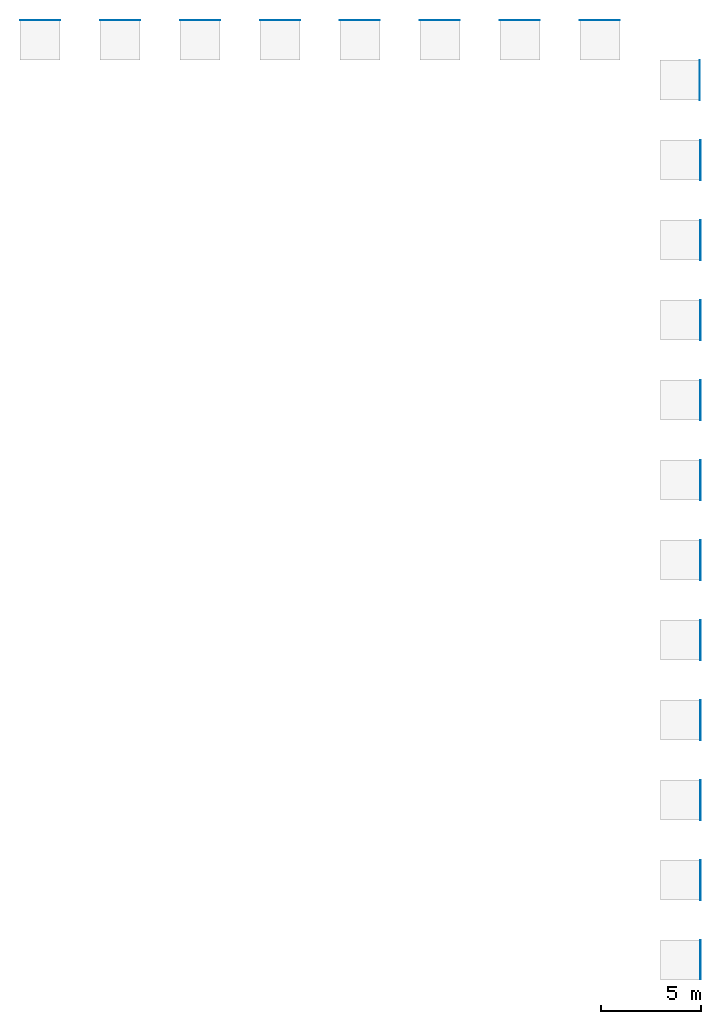
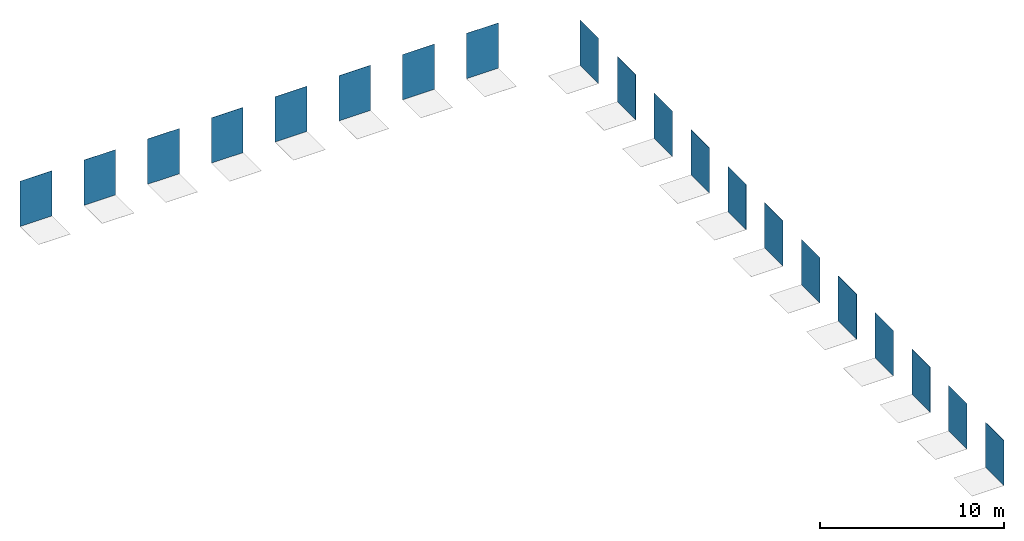
# One storey, part 1 of 2: 20 walls.
"""IFC2X3 building model written with IfcOpenShell, lengths in millimetres."""

from ifc_helpers import new_model, entity, si_unit, converted_unit, derived_unit, direction, frame, frame_2d, origin, place, context, subcontext, project, spatial, rectangle, extrude, material, layer, layer_set, layer_usage, type_object, element, save


model = new_model("IFC2X3")

# Units and contexts
model_context = context("Model", 3, precision=0.01, world=origin(), true_north=direction((6.12303176911189e-17, 1.0)))
body_context = subcontext(model_context, "Body", "Model", "MODEL_VIEW")
ifc_project = project(units=[si_unit("LENGTHUNIT", "METRE", prefix="MILLI"), si_unit("AREAUNIT", "SQUARE_METRE"), si_unit("VOLUMEUNIT", "CUBIC_METRE"), converted_unit("PLANEANGLEUNIT", "DEGREE", entity("IfcRatioMeasure", 0.0174532925199433), si_unit("PLANEANGLEUNIT", "RADIAN"), dimensions=[0, 0, 0, 0, 0, 0, 0]), si_unit("MASSUNIT", "GRAM", prefix="KILO"), derived_unit("MASSDENSITYUNIT", [(si_unit("MASSUNIT", "GRAM", prefix="KILO"), 1), (si_unit("LENGTHUNIT", "METRE"), -3)]), si_unit("TIMEUNIT", "SECOND"), si_unit("FREQUENCYUNIT", "HERTZ"), si_unit("THERMODYNAMICTEMPERATUREUNIT", "DEGREE_CELSIUS"), derived_unit("THERMALTRANSMITTANCEUNIT", [(si_unit("MASSUNIT", "GRAM", prefix="KILO"), 1), (si_unit("THERMODYNAMICTEMPERATUREUNIT", "KELVIN"), -1), (si_unit("TIMEUNIT", "SECOND"), -3)]), derived_unit("VOLUMETRICFLOWRATEUNIT", [(si_unit("LENGTHUNIT", "METRE"), 3), (si_unit("TIMEUNIT", "SECOND"), -1)]), si_unit("ELECTRICCURRENTUNIT", "AMPERE"), si_unit("ELECTRICVOLTAGEUNIT", "VOLT"), si_unit("POWERUNIT", "WATT"), si_unit("FORCEUNIT", "NEWTON", prefix="KILO"), si_unit("ILLUMINANCEUNIT", "LUX"), si_unit("LUMINOUSFLUXUNIT", "LUMEN"), si_unit("LUMINOUSINTENSITYUNIT", "CANDELA"), derived_unit("USERDEFINED", [(si_unit("MASSUNIT", "GRAM", prefix="KILO"), -1), (si_unit("LENGTHUNIT", "METRE"), -2), (si_unit("TIMEUNIT", "SECOND"), 3), (si_unit("LUMINOUSFLUXUNIT", "LUMEN"), 1)]), derived_unit("LINEARVELOCITYUNIT", [(si_unit("LENGTHUNIT", "METRE"), 1), (si_unit("TIMEUNIT", "SECOND"), -1)]), si_unit("PRESSUREUNIT", "PASCAL"), derived_unit("USERDEFINED", [(si_unit("LENGTHUNIT", "METRE"), -2), (si_unit("MASSUNIT", "GRAM", prefix="KILO"), 1), (si_unit("TIMEUNIT", "SECOND"), -2)])], contexts=[model_context])

# Site, building, storey
site_placement = place(None, origin())
site = spatial("IfcSite", under=ifc_project, at=site_placement, CompositionType="ELEMENT")
building_placement = place(site_placement, origin())
building = spatial("IfcBuilding", under=site, at=building_placement, CompositionType="ELEMENT")
storey_placement = place(building_placement, origin())
storey = spatial("IfcBuildingStorey", under=building, at=storey_placement, Name="Level 1", CompositionType="ELEMENT", Elevation=0.0)

# Walls
ifc_material_1 = material(Name="PGR_CeramicTiles_Acero-193x1200mm")
ifc_layer_1 = layer(ifc_material_1, 11.5)
ifc_layer_set_1 = layer_set([ifc_layer_1], Name="Basic Wall:PGR_CeramicTiles_Acero-193x1200mm")
ifc_layer_usage_1 = layer_usage(ifc_layer_set_1, "AXIS2", "POSITIVE", -5.75)
wall_type_1 = type_object("IfcWallType", Name="Basic Wall:PGR_CeramicTiles_Acero-193x1200mm", PredefinedType="STANDARD", material=ifc_layer_set_1)
wall_1_placement = place(storey_placement, frame((3521.32742659015, 25498.0173252312, 0.0), z_axis=(0.0, 0.0, 1.0), x_axis=(0.0, -1.0, 0.0)))
element("IfcWallStandardCase", 1, at=wall_1_placement, inside=storey, type_object=wall_type_1, material=ifc_layer_usage_1, Name="Basic Wall:PGR_CeramicTiles_Acero-193x1200mm", ObjectType="Basic Wall:PGR_CeramicTiles_Acero-193x1200mm", context=body_context, shape_type="SweptSolid", body=[
    extrude(rectangle(XDim=2000.0, YDim=11.4999999999996, at=frame_2d((1000.0, 7.54951656745106e-15), x_axis=(-1.0, 0.0))), origin(), (0.0, 0.0, 1.0), 3000.00000000014),
])
ifc_material_2 = material(Name="PGR_CeramicTiles_Acero-193x1800mm")
ifc_layer_2 = layer(ifc_material_2, 11.5)
ifc_layer_set_2 = layer_set([ifc_layer_2], Name="Basic Wall:PGR_CeramicTiles_Acero-193x1800mm")
ifc_layer_usage_2 = layer_usage(ifc_layer_set_2, "AXIS2", "POSITIVE", -5.75)
wall_type_2 = type_object("IfcWallType", Name="Basic Wall:PGR_CeramicTiles_Acero-193x1800mm", PredefinedType="STANDARD", material=ifc_layer_set_2)
wall_2_placement = place(storey_placement, frame((3521.32742659015, 29498.0173252312, 0.0), z_axis=(0.0, 0.0, 1.0), x_axis=(0.0, -1.0, 0.0)))
element("IfcWallStandardCase", 2, at=wall_2_placement, inside=storey, type_object=wall_type_2, material=ifc_layer_usage_2, Name="Basic Wall:PGR_CeramicTiles_Acero-193x1800mm", ObjectType="Basic Wall:PGR_CeramicTiles_Acero-193x1800mm", context=body_context, shape_type="SweptSolid", body=[
    extrude(rectangle(XDim=2000.0, YDim=11.4999999999996, at=frame_2d((1000.0, 7.54951656745106e-15), x_axis=(-1.0, 0.0))), origin(), (0.0, 0.0, 1.0), 3000.00000000014),
])
ifc_material_3 = material(Name="PGR_CeramicTiles_Acero-294x1200mm")
ifc_layer_3 = layer(ifc_material_3, 11.5)
ifc_layer_set_3 = layer_set([ifc_layer_3], Name="Basic Wall:PGR_CeramicTiles_Acero-294x1200mm")
ifc_layer_usage_3 = layer_usage(ifc_layer_set_3, "AXIS2", "POSITIVE", -5.75)
wall_type_3 = type_object("IfcWallType", Name="Basic Wall:PGR_CeramicTiles_Acero-294x1200mm", PredefinedType="STANDARD", material=ifc_layer_set_3)
wall_3_placement = place(storey_placement, frame((-2498.42257340996, 71492.2673252312, 0.0)))
element("IfcWallStandardCase", 3, at=wall_3_placement, inside=storey, type_object=wall_type_3, material=ifc_layer_usage_3, Name="Basic Wall:PGR_CeramicTiles_Acero-294x1200mm", ObjectType="Basic Wall:PGR_CeramicTiles_Acero-294x1200mm", context=body_context, shape_type="SweptSolid", body=[
    extrude(rectangle(XDim=2000.0, YDim=11.500000000006, at=frame_2d((1000.0, 1.8052226380405e-12), x_axis=(-1.0, 0.0))), origin(), (0.0, 0.0, 1.0), 3000.00000000014),
])
ifc_material_4 = material(Name="PGR_CeramicTiles_Acero-294x1800mm")
ifc_layer_4 = layer(ifc_material_4, 11.5)
ifc_layer_set_4 = layer_set([ifc_layer_4], Name="Basic Wall:PGR_CeramicTiles_Acero-294x1800mm")
ifc_layer_usage_4 = layer_usage(ifc_layer_set_4, "AXIS2", "POSITIVE", -5.75)
wall_type_4 = type_object("IfcWallType", Name="Basic Wall:PGR_CeramicTiles_Acero-294x1800mm", PredefinedType="STANDARD", material=ifc_layer_set_4)
wall_4_placement = place(storey_placement, frame((-6498.42257340995, 71492.2673252312, 0.0)))
element("IfcWallStandardCase", 4, at=wall_4_placement, inside=storey, type_object=wall_type_4, material=ifc_layer_usage_4, Name="Basic Wall:PGR_CeramicTiles_Acero-294x1800mm", ObjectType="Basic Wall:PGR_CeramicTiles_Acero-294x1800mm", context=body_context, shape_type="SweptSolid", body=[
    extrude(rectangle(XDim=2000.0, YDim=11.500000000006, at=frame_2d((1000.0, 1.8052226380405e-12), x_axis=(-1.0, 0.0))), origin(), (0.0, 0.0, 1.0), 3000.00000000014),
])
ifc_material_5 = material(Name="PGR_CeramicTiles_Acero_Ant.-193x1800mm")
ifc_layer_5 = layer(ifc_material_5, 11.5)
ifc_layer_set_5 = layer_set([ifc_layer_5], Name="Basic Wall:PGR_CeramicTiles_Acero_Ant.-193x1800mm")
ifc_layer_usage_5 = layer_usage(ifc_layer_set_5, "AXIS2", "POSITIVE", -5.75)
wall_type_5 = type_object("IfcWallType", Name="Basic Wall:PGR_CeramicTiles_Acero_Ant.-193x1800mm", PredefinedType="STANDARD", material=ifc_layer_set_5)
wall_5_placement = place(storey_placement, frame((3521.32742659013, 33498.0173252312, 0.0), z_axis=(0.0, 0.0, 1.0), x_axis=(0.0, -1.0, 0.0)))
element("IfcWallStandardCase", 5, at=wall_5_placement, inside=storey, type_object=wall_type_5, material=ifc_layer_usage_5, Name="Basic Wall:PGR_CeramicTiles_Acero_Ant.-193x1800mm", ObjectType="Basic Wall:PGR_CeramicTiles_Acero_Ant.-193x1800mm", context=body_context, shape_type="SweptSolid", body=[
    extrude(rectangle(XDim=2000.0, YDim=11.4999999999996, at=frame_2d((1000.0, 7.54951656745106e-15), x_axis=(-1.0, 0.0))), origin(), (0.0, 0.0, 1.0), 3000.00000000014),
])
ifc_material_6 = material(Name="PGR_CeramicTiles_Arce-193x1200mm")
ifc_layer_6 = layer(ifc_material_6, 11.5)
ifc_layer_set_6 = layer_set([ifc_layer_6], Name="Basic Wall:PGR_CeramicTiles_Arce-193x1200mm")
ifc_layer_usage_6 = layer_usage(ifc_layer_set_6, "AXIS2", "POSITIVE", -5.75)
wall_type_6 = type_object("IfcWallType", Name="Basic Wall:PGR_CeramicTiles_Arce-193x1200mm", PredefinedType="STANDARD", material=ifc_layer_set_6)
wall_6_placement = place(storey_placement, frame((3521.32742659013, 37498.0173252312, 0.0), z_axis=(0.0, 0.0, 1.0), x_axis=(0.0, -1.0, 0.0)))
element("IfcWallStandardCase", 6, at=wall_6_placement, inside=storey, type_object=wall_type_6, material=ifc_layer_usage_6, Name="Basic Wall:PGR_CeramicTiles_Arce-193x1200mm", ObjectType="Basic Wall:PGR_CeramicTiles_Arce-193x1200mm", context=body_context, shape_type="SweptSolid", body=[
    extrude(rectangle(XDim=2000.0, YDim=11.4999999999996, at=frame_2d((1000.0, 7.54951656745106e-15), x_axis=(-1.0, 0.0))), origin(), (0.0, 0.0, 1.0), 3000.00000000014),
])
ifc_material_7 = material(Name="PGR_CeramicTiles_Arce-193x1800mm")
ifc_layer_7 = layer(ifc_material_7, 11.5)
ifc_layer_set_7 = layer_set([ifc_layer_7], Name="Basic Wall:PGR_CeramicTiles_Arce-193x1800mm")
ifc_layer_usage_7 = layer_usage(ifc_layer_set_7, "AXIS2", "POSITIVE", -5.75)
wall_type_7 = type_object("IfcWallType", Name="Basic Wall:PGR_CeramicTiles_Arce-193x1800mm", PredefinedType="STANDARD", material=ifc_layer_set_7)
wall_7_placement = place(storey_placement, frame((3521.32742659013, 41498.0173252312, 0.0), z_axis=(0.0, 0.0, 1.0), x_axis=(0.0, -1.0, 0.0)))
element("IfcWallStandardCase", 7, at=wall_7_placement, inside=storey, type_object=wall_type_7, material=ifc_layer_usage_7, Name="Basic Wall:PGR_CeramicTiles_Arce-193x1800mm", ObjectType="Basic Wall:PGR_CeramicTiles_Arce-193x1800mm", context=body_context, shape_type="SweptSolid", body=[
    extrude(rectangle(XDim=2000.0, YDim=11.4999999999996, at=frame_2d((1000.0, 7.54951656745106e-15), x_axis=(-1.0, 0.0))), origin(), (0.0, 0.0, 1.0), 3000.00000000014),
])
ifc_material_8 = material(Name="PGR_CeramicTiles_Arce-294x1200mm")
ifc_layer_8 = layer(ifc_material_8, 11.5)
ifc_layer_set_8 = layer_set([ifc_layer_8], Name="Basic Wall:PGR_CeramicTiles_Arce-294x1200mm")
ifc_layer_usage_8 = layer_usage(ifc_layer_set_8, "AXIS2", "POSITIVE", -5.75)
wall_type_8 = type_object("IfcWallType", Name="Basic Wall:PGR_CeramicTiles_Arce-294x1200mm", PredefinedType="STANDARD", material=ifc_layer_set_8)
wall_8_placement = place(storey_placement, frame((-10498.42257341, 71492.2673252312, 0.0)))
element("IfcWallStandardCase", 8, at=wall_8_placement, inside=storey, type_object=wall_type_8, material=ifc_layer_usage_8, Name="Basic Wall:PGR_CeramicTiles_Arce-294x1200mm", ObjectType="Basic Wall:PGR_CeramicTiles_Arce-294x1200mm", context=body_context, shape_type="SweptSolid", body=[
    extrude(rectangle(XDim=2000.0, YDim=11.500000000006, at=frame_2d((1000.0, 1.8052226380405e-12), x_axis=(-1.0, 0.0))), origin(), (0.0, 0.0, 1.0), 3000.00000000014),
])
ifc_material_9 = material(Name="PGR_CeramicTiles_Arce-294x1800mm")
ifc_layer_9 = layer(ifc_material_9, 11.5)
ifc_layer_set_9 = layer_set([ifc_layer_9], Name="Basic Wall:PGR_CeramicTiles_Arce-294x1800mm")
ifc_layer_usage_9 = layer_usage(ifc_layer_set_9, "AXIS2", "POSITIVE", -5.75)
wall_type_9 = type_object("IfcWallType", Name="Basic Wall:PGR_CeramicTiles_Arce-294x1800mm", PredefinedType="STANDARD", material=ifc_layer_set_9)
wall_9_placement = place(storey_placement, frame((-14498.42257341, 71492.2673252312, 0.0)))
element("IfcWallStandardCase", 9, at=wall_9_placement, inside=storey, type_object=wall_type_9, material=ifc_layer_usage_9, Name="Basic Wall:PGR_CeramicTiles_Arce-294x1800mm", ObjectType="Basic Wall:PGR_CeramicTiles_Arce-294x1800mm", context=body_context, shape_type="SweptSolid", body=[
    extrude(rectangle(XDim=2000.0, YDim=11.500000000006, at=frame_2d((1000.0, 1.8052226380405e-12), x_axis=(-1.0, 0.0))), origin(), (0.0, 0.0, 1.0), 3000.00000000014),
])
ifc_material_10 = material(Name="PGR_CeramicTiles_Arce_Ant.-193x1800mm")
ifc_layer_10 = layer(ifc_material_10, 11.5)
ifc_layer_set_10 = layer_set([ifc_layer_10], Name="Basic Wall:PGR_CeramicTiles_Arce_Ant.-193x1800mm")
ifc_layer_usage_10 = layer_usage(ifc_layer_set_10, "AXIS2", "POSITIVE", -5.75)
wall_type_10 = type_object("IfcWallType", Name="Basic Wall:PGR_CeramicTiles_Arce_Ant.-193x1800mm", PredefinedType="STANDARD", material=ifc_layer_set_10)
wall_10_placement = place(storey_placement, frame((3521.32742659012, 45498.0173252312, 0.0), z_axis=(0.0, 0.0, 1.0), x_axis=(0.0, -1.0, 0.0)))
element("IfcWallStandardCase", 10, at=wall_10_placement, inside=storey, type_object=wall_type_10, material=ifc_layer_usage_10, Name="Basic Wall:PGR_CeramicTiles_Arce_Ant.-193x1800mm", ObjectType="Basic Wall:PGR_CeramicTiles_Arce_Ant.-193x1800mm", context=body_context, shape_type="SweptSolid", body=[
    extrude(rectangle(XDim=2000.0, YDim=11.4999999999996, at=frame_2d((1000.0, 7.54951656745106e-15), x_axis=(-1.0, 0.0))), origin(), (0.0, 0.0, 1.0), 3000.00000000014),
])
ifc_material_11 = material(Name="PGR_CeramicTiles_Natural-193x1200mm")
ifc_layer_11 = layer(ifc_material_11, 11.5)
ifc_layer_set_11 = layer_set([ifc_layer_11], Name="Basic Wall:PGR_CeramicTiles_Natural-193x1200mm")
ifc_layer_usage_11 = layer_usage(ifc_layer_set_11, "AXIS2", "POSITIVE", -5.75)
wall_type_11 = type_object("IfcWallType", Name="Basic Wall:PGR_CeramicTiles_Natural-193x1200mm", PredefinedType="STANDARD", material=ifc_layer_set_11)
wall_11_placement = place(storey_placement, frame((3521.32742659014, 49498.0173252312, 0.0), z_axis=(0.0, 0.0, 1.0), x_axis=(0.0, -1.0, 0.0)))
element("IfcWallStandardCase", 11, at=wall_11_placement, inside=storey, type_object=wall_type_11, material=ifc_layer_usage_11, Name="Basic Wall:PGR_CeramicTiles_Natural-193x1200mm", ObjectType="Basic Wall:PGR_CeramicTiles_Natural-193x1200mm", context=body_context, shape_type="SweptSolid", body=[
    extrude(rectangle(XDim=2000.0, YDim=11.4999999999996, at=frame_2d((1000.0, 8.39328606616618e-14), x_axis=(-1.0, 0.0))), origin(), (0.0, 0.0, 1.0), 3000.00000000014),
])
ifc_material_12 = material(Name="PGR_CeramicTiles_Natural-193x1800mm")
ifc_layer_12 = layer(ifc_material_12, 11.5)
ifc_layer_set_12 = layer_set([ifc_layer_12], Name="Basic Wall:PGR_CeramicTiles_Natural-193x1800mm")
ifc_layer_usage_12 = layer_usage(ifc_layer_set_12, "AXIS2", "POSITIVE", -5.75)
wall_type_12 = type_object("IfcWallType", Name="Basic Wall:PGR_CeramicTiles_Natural-193x1800mm", PredefinedType="STANDARD", material=ifc_layer_set_12)
wall_12_placement = place(storey_placement, frame((3521.32742659014, 53498.0173252312, 0.0), z_axis=(0.0, 0.0, 1.0), x_axis=(0.0, -1.0, 0.0)))
element("IfcWallStandardCase", 12, at=wall_12_placement, inside=storey, type_object=wall_type_12, material=ifc_layer_usage_12, Name="Basic Wall:PGR_CeramicTiles_Natural-193x1800mm", ObjectType="Basic Wall:PGR_CeramicTiles_Natural-193x1800mm", context=body_context, shape_type="SweptSolid", body=[
    extrude(rectangle(XDim=2000.0, YDim=11.4999999999996, at=frame_2d((1000.0, 8.39328606616618e-14), x_axis=(-1.0, 0.0))), origin(), (0.0, 0.0, 1.0), 3000.00000000014),
])
ifc_material_13 = material(Name="PGR_CeramicTiles_Natural-294x1200mm")
ifc_layer_13 = layer(ifc_material_13, 11.5)
ifc_layer_set_13 = layer_set([ifc_layer_13], Name="Basic Wall:PGR_CeramicTiles_Natural-294x1200mm")
ifc_layer_usage_13 = layer_usage(ifc_layer_set_13, "AXIS2", "POSITIVE", -5.75)
wall_type_13 = type_object("IfcWallType", Name="Basic Wall:PGR_CeramicTiles_Natural-294x1200mm", PredefinedType="STANDARD", material=ifc_layer_set_13)
wall_13_placement = place(storey_placement, frame((-18498.4225734099, 71492.2673252312, 0.0)))
element("IfcWallStandardCase", 13, at=wall_13_placement, inside=storey, type_object=wall_type_13, material=ifc_layer_usage_13, Name="Basic Wall:PGR_CeramicTiles_Natural-294x1200mm", ObjectType="Basic Wall:PGR_CeramicTiles_Natural-294x1200mm", context=body_context, shape_type="SweptSolid", body=[
    extrude(rectangle(XDim=2000.0, YDim=11.5000000000061, at=frame_2d((1000.0, -1.36024524977074e-12), x_axis=(-1.0, 0.0))), origin(), (0.0, 0.0, 1.0), 3000.00000000014),
])
ifc_material_14 = material(Name="PGR_CeramicTiles_Natural-294x1800mm")
ifc_layer_14 = layer(ifc_material_14, 11.5)
ifc_layer_set_14 = layer_set([ifc_layer_14], Name="Basic Wall:PGR_CeramicTiles_Natural-294x1800mm")
ifc_layer_usage_14 = layer_usage(ifc_layer_set_14, "AXIS2", "POSITIVE", -5.75)
wall_type_14 = type_object("IfcWallType", Name="Basic Wall:PGR_CeramicTiles_Natural-294x1800mm", PredefinedType="STANDARD", material=ifc_layer_set_14)
wall_14_placement = place(storey_placement, frame((-22498.4225734099, 71492.2673252312, 0.0)))
element("IfcWallStandardCase", 14, at=wall_14_placement, inside=storey, type_object=wall_type_14, material=ifc_layer_usage_14, Name="Basic Wall:PGR_CeramicTiles_Natural-294x1800mm", ObjectType="Basic Wall:PGR_CeramicTiles_Natural-294x1800mm", context=body_context, shape_type="SweptSolid", body=[
    extrude(rectangle(XDim=2000.0, YDim=11.5000000000061, at=frame_2d((1000.0, -1.36024524977074e-12), x_axis=(-1.0, 0.0))), origin(), (0.0, 0.0, 1.0), 3000.00000000014),
])
ifc_material_15 = material(Name="PGR_CeramicTiles_Natural_Ant.-193x1800mm")
ifc_layer_15 = layer(ifc_material_15, 11.5)
ifc_layer_set_15 = layer_set([ifc_layer_15], Name="Basic Wall:PGR_CeramicTiles_Natural_Ant.-193x1800mm")
ifc_layer_usage_15 = layer_usage(ifc_layer_set_15, "AXIS2", "POSITIVE", -5.75)
wall_type_15 = type_object("IfcWallType", Name="Basic Wall:PGR_CeramicTiles_Natural_Ant.-193x1800mm", PredefinedType="STANDARD", material=ifc_layer_set_15)
wall_15_placement = place(storey_placement, frame((3521.32742659014, 57498.0173252312, 0.0), z_axis=(0.0, 0.0, 1.0), x_axis=(0.0, -1.0, 0.0)))
element("IfcWallStandardCase", 15, at=wall_15_placement, inside=storey, type_object=wall_type_15, material=ifc_layer_usage_15, Name="Basic Wall:PGR_CeramicTiles_Natural_Ant.-193x1800mm", ObjectType="Basic Wall:PGR_CeramicTiles_Natural_Ant.-193x1800mm", context=body_context, shape_type="SweptSolid", body=[
    extrude(rectangle(XDim=2000.0, YDim=11.4999999999996, at=frame_2d((1000.0, -1.25233157177718e-13), x_axis=(-1.0, 0.0))), origin(), (0.0, 0.0, 1.0), 3000.00000000014),
])
ifc_material_16 = material(Name="PGR_CeramicTiles_193x1200mm")
ifc_layer_16 = layer(ifc_material_16, 11.5)
ifc_layer_set_16 = layer_set([ifc_layer_16], Name="Basic Wall:PGR_CeramicTiles_193x1200mm")
ifc_layer_usage_16 = layer_usage(ifc_layer_set_16, "AXIS2", "POSITIVE", -5.75)
wall_type_16 = type_object("IfcWallType", Name="Basic Wall:PGR_CeramicTiles_193x1200mm", PredefinedType="STANDARD", material=ifc_layer_set_16)
wall_16_placement = place(storey_placement, frame((3521.32742659014, 61498.0173252312, 0.0), z_axis=(0.0, 0.0, 1.0), x_axis=(0.0, -1.0, 0.0)))
element("IfcWallStandardCase", 16, at=wall_16_placement, inside=storey, type_object=wall_type_16, material=ifc_layer_usage_16, Name="Basic Wall:PGR_CeramicTiles_193x1200mm", ObjectType="Basic Wall:PGR_CeramicTiles_193x1200mm", context=body_context, shape_type="SweptSolid", body=[
    extrude(rectangle(XDim=2000.0, YDim=11.4999999999996, at=frame_2d((1000.0, -1.25233157177718e-13), x_axis=(-1.0, 0.0))), origin(), (0.0, 0.0, 1.0), 3000.00000000014),
])
ifc_material_17 = material(Name="PGR_CeramicTiles_193x1800mm")
ifc_layer_17 = layer(ifc_material_17, 11.5)
ifc_layer_set_17 = layer_set([ifc_layer_17], Name="Basic Wall:PGR_CeramicTiles_193x1800mm")
ifc_layer_usage_17 = layer_usage(ifc_layer_set_17, "AXIS2", "POSITIVE", -5.75)
wall_type_17 = type_object("IfcWallType", Name="Basic Wall:PGR_CeramicTiles_193x1800mm", PredefinedType="STANDARD", material=ifc_layer_set_17)
wall_17_placement = place(storey_placement, frame((3521.32742659017, 65498.0173252312, 0.0), z_axis=(0.0, 0.0, 1.0), x_axis=(0.0, -1.0, 0.0)))
element("IfcWallStandardCase", 17, at=wall_17_placement, inside=storey, type_object=wall_type_17, material=ifc_layer_usage_17, Name="Basic Wall:PGR_CeramicTiles_193x1800mm", ObjectType="Basic Wall:PGR_CeramicTiles_193x1800mm", context=body_context, shape_type="SweptSolid", body=[
    extrude(rectangle(XDim=2000.0, YDim=11.4999999999996, at=frame_2d((1000.0, -1.25233157177718e-13), x_axis=(-1.0, 0.0))), origin(), (0.0, 0.0, 1.0), 3000.00000000014),
])
ifc_material_18 = material(Name="PGR_CeramicTiles_294x1200mm")
ifc_layer_18 = layer(ifc_material_18, 11.5)
ifc_layer_set_18 = layer_set([ifc_layer_18], Name="Basic Wall:PGR_CeramicTiles_294x1200mm")
ifc_layer_usage_18 = layer_usage(ifc_layer_set_18, "AXIS2", "POSITIVE", -5.75)
wall_type_18 = type_object("IfcWallType", Name="Basic Wall:PGR_CeramicTiles_294x1200mm", PredefinedType="STANDARD", material=ifc_layer_set_18)
wall_18_placement = place(storey_placement, frame((-26498.4225734099, 71492.2673252312, 0.0)))
element("IfcWallStandardCase", 18, at=wall_18_placement, inside=storey, type_object=wall_type_18, material=ifc_layer_usage_18, Name="Basic Wall:PGR_CeramicTiles_294x1200mm", ObjectType="Basic Wall:PGR_CeramicTiles_294x1200mm", context=body_context, shape_type="SweptSolid", body=[
    extrude(rectangle(XDim=2000.0, YDim=11.5000000000061, at=frame_2d((1000.0, -1.36024524977074e-12), x_axis=(-1.0, 0.0))), origin(), (0.0, 0.0, 1.0), 3000.00000000014),
])
ifc_material_19 = material(Name="PGR_CeramicTiles_294x1800mm")
ifc_layer_19 = layer(ifc_material_19, 11.5)
ifc_layer_set_19 = layer_set([ifc_layer_19], Name="Basic Wall:PGR_CeramicTiles_294x1800mm")
ifc_layer_usage_19 = layer_usage(ifc_layer_set_19, "AXIS2", "POSITIVE", -5.75)
wall_type_19 = type_object("IfcWallType", Name="Basic Wall:PGR_CeramicTiles_294x1800mm", PredefinedType="STANDARD", material=ifc_layer_set_19)
wall_19_placement = place(storey_placement, frame((-30498.4225734099, 71492.2673252312, 0.0)))
element("IfcWallStandardCase", 19, at=wall_19_placement, inside=storey, type_object=wall_type_19, material=ifc_layer_usage_19, Name="Basic Wall:PGR_CeramicTiles_294x1800mm", ObjectType="Basic Wall:PGR_CeramicTiles_294x1800mm", context=body_context, shape_type="SweptSolid", body=[
    extrude(rectangle(XDim=2000.0, YDim=11.5000000000061, at=frame_2d((1000.0, -1.36024524977074e-12), x_axis=(-1.0, 0.0))), origin(), (0.0, 0.0, 1.0), 3000.00000000014),
])
ifc_material_20 = material(Name="PGR_CeramicTiles_Ant.-193x1800mm")
ifc_layer_20 = layer(ifc_material_20, 11.5)
ifc_layer_set_20 = layer_set([ifc_layer_20], Name="Basic Wall:PGR_CeramicTiles_Ant.-193x1800mm")
ifc_layer_usage_20 = layer_usage(ifc_layer_set_20, "AXIS2", "POSITIVE", -5.75)
wall_type_20 = type_object("IfcWallType", Name="Basic Wall:PGR_CeramicTiles_Ant.-193x1800mm", PredefinedType="STANDARD", material=ifc_layer_set_20)
wall_20_placement = place(storey_placement, frame((3495.82742659006, 69498.0173252312, 0.0), z_axis=(0.0, 0.0, 1.0), x_axis=(0.0, -1.0, 0.0)))
element("IfcWallStandardCase", 20, at=wall_20_placement, inside=storey, type_object=wall_type_20, material=ifc_layer_usage_20, Name="Basic Wall:PGR_CeramicTiles_Ant.-193x1800mm", ObjectType="Basic Wall:PGR_CeramicTiles_Ant.-193x1800mm", context=body_context, shape_type="SweptSolid", body=[
    extrude(rectangle(XDim=2000.0, YDim=11.4999999999996, at=frame_2d((1000.0, -1.25233157177718e-13), x_axis=(-1.0, 0.0))), origin(), (0.0, 0.0, 1.0), 3000.00000000014),
])

save(model, "model.ifc")
